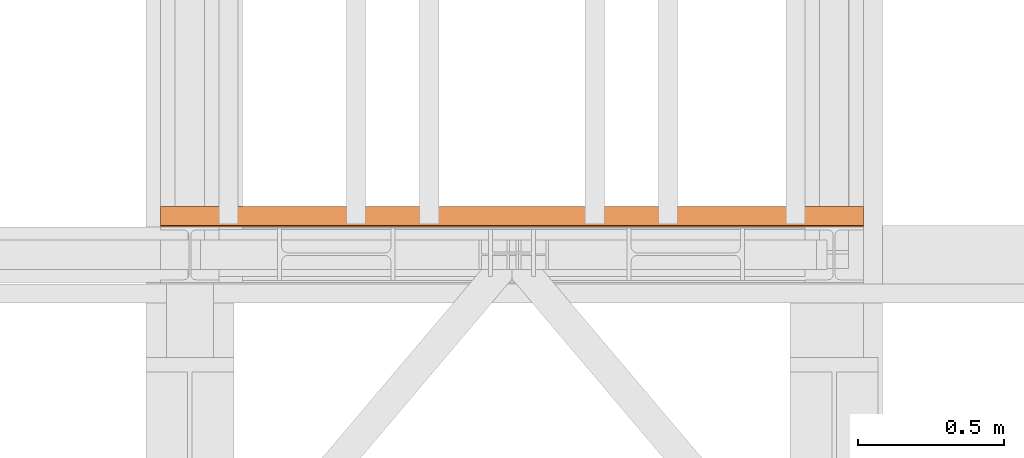
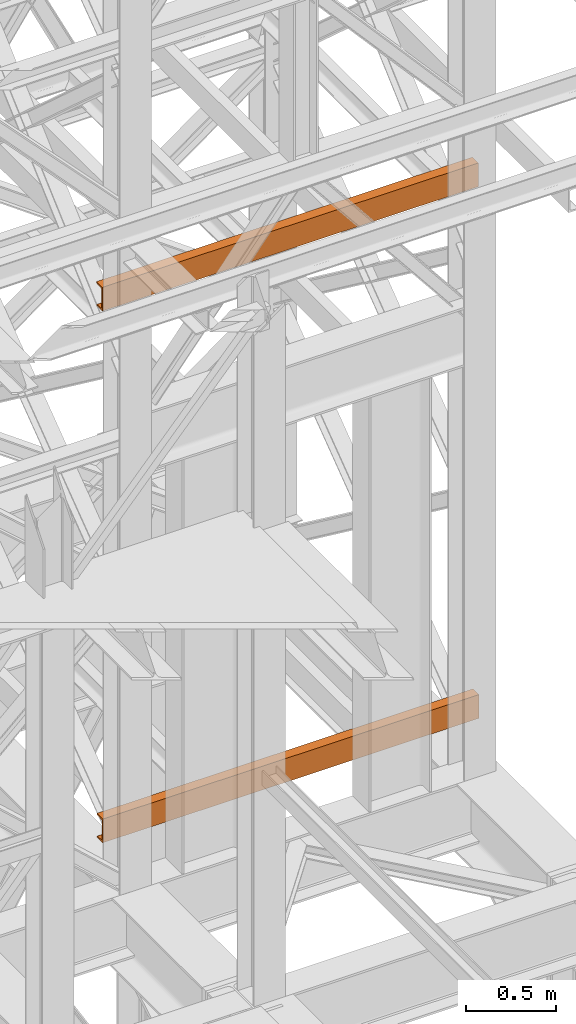
# One storey, part 179 of 208: 2 proxies.
"""IFC2X3 building model written with IfcOpenShell, lengths in millimetres."""

from ifc_helpers import new_model, entity, si_unit, converted_unit, frame, origin, origin_with_axes, place, context, subcontext, project, spatial, faceted_brep, element, save


model = new_model("IFC2X3")

# Units and contexts
model_context = context("Model", 3, precision=1e-05, world=origin())
plan_context = context("Plan", 3, precision=1e-05, world=origin())
body_context = subcontext(model_context, "Body", "Model", "MODEL_VIEW")
ifc_project = project(units=[si_unit("LENGTHUNIT", "METRE", prefix="MILLI"), converted_unit("PLANEANGLEUNIT", "DEGREE", entity("IfcPlaneAngleMeasure", 0.0174532925199433), si_unit("PLANEANGLEUNIT", "RADIAN"), dimensions=[0, 0, 0, 0, 0, 0, 0]), si_unit("AREAUNIT", "SQUARE_METRE"), si_unit("VOLUMEUNIT", "CUBIC_METRE")], contexts=[model_context, plan_context])

# Building, storey
building_placement = place(None, origin())
building = spatial("IfcBuilding", under=ifc_project, at=building_placement, CompositionType="COMPLEX")
storey_placement = place(building_placement, origin_with_axes())
storey = spatial("IfcBuildingStorey", under=building, at=storey_placement, Name="Geschoss", CompositionType="ELEMENT")

# Proxies
proxy_1_placement = place(storey_placement, frame((6493.302372304859, -15862.57438797436, 9109.989999999998), z_axis=(0.0, 0.0, 1.0), x_axis=(1.0, 0.0, 0.0)))
element("IfcBuildingElementProxy", 1, at=proxy_1_placement, inside=storey, context=body_context, shape_type="Brep", body=[
    faceted_brep([(2399.962597713924, 0.01853275732537441, 160.0100000000002), (0.009999999999308784, 0.00999999999839929, 160.0100000000002), (0.009999999999308784, 65.0099999999984, 160.0100000000002), (2399.962597713924, 65.01853275732537, 160.0100000000002), (2399.962597713924, 65.01853275732537, 160.0100000000002), (0.009999999999308784, 65.0099999999984, 160.0100000000002), (0.009999999999308784, 65.0099999999984, 156.8875719297539), (2399.962597713924, 65.01853275732537, 156.8875719297539), (2399.962597713924, 65.01853275732537, 156.8875719297539), (0.009999999999308784, 65.0099999999984, 156.8875719297539), (0.009999999999308784, 64.76726342282564, 155.2717110918293), (2399.962597713924, 64.77579618015261, 155.2717110918293), (2399.962597713924, 64.77579618015261, 155.2717110918293), (0.009999999999308784, 64.76726342282564, 155.2717110918293), (0.009999999999308784, 64.06053228585733, 153.7984655565542), (2399.962597713924, 64.06906504318067, 153.7984655565542), (2399.962597713924, 64.06906504318067, 153.7984655565542), (0.009999999999308784, 64.06053228585733, 153.7984655565542), (0.009999999999308784, 62.9521516384666, 152.5978732961266), (2399.962597713924, 62.96068439579358, 152.5978732961266), (2399.962597713924, 62.96068439579358, 152.5978732961266), (0.009999999999308784, 62.9521516384666, 152.5978732961266), (0.009999999999308784, 61.5399564114814, 151.7759086082897), (2399.962597713924, 61.54848916880837, 151.7759086082897), (2399.962597713924, 61.54848916880837, 151.7759086082897), (0.009999999999308784, 61.5399564114814, 151.7759086082897), (0.009999999999308784, 59.94859872255256, 151.4050878978051), (2399.962597713924, 59.95713147987954, 151.4050878978051), (2399.962597713924, 59.95713147987954, 151.4050878978051), (0.009999999999308784, 59.94859872255256, 151.4050878978051), (0.009999999999308784, 17.17267516602806, 147.9830140132835), (2399.962597713924, 17.18120792335503, 147.9830140132835), (2399.962597713924, 17.18120792335503, 147.9830140132835), (0.009999999999308784, 17.17267516602806, 147.9830140132835), (0.009999999999308784, 14.20840820800731, 147.318026761528), (2399.962597713924, 14.21694096533429, 147.318026761528), (2399.962597713924, 14.21694096533429, 147.318026761528), (0.009999999999308784, 14.20840820800731, 147.318026761528), (0.009999999999308784, 11.43861959928836, 145.7058782528511), (2399.962597713924, 11.4471523566117, 145.7058782528511), (2399.962597713924, 11.4471523566117, 145.7058782528511), (0.009999999999308784, 11.43861959928836, 145.7058782528511), (0.009999999999308784, 9.322620181545062, 143.4138384829421), (2399.962597713924, 9.331152938872037, 143.4138384829421), (2399.962597713924, 9.331152938872037, 143.4138384829421), (0.009999999999308784, 9.322620181545062, 143.4138384829421), (0.009999999999308784, 7.973406192784751, 140.6012788246917), (2399.962597713924, 7.981938950111726, 140.6012788246917), (2399.962597713924, 7.981938950111726, 140.6012788246917), (0.009999999999308784, 7.973406192784751, 140.6012788246917), (0.009999999999308784, 7.509999999998399, 137.5164535886543), (2399.962597713924, 7.518532757325374, 137.5164535886543), (2399.962597713924, 7.518532757325374, 137.5164535886543), (0.009999999999308784, 7.509999999998399, 137.5164535886543), (0.009999999999308784, 7.509999999998399, 22.503546411348), (2399.962597713924, 7.518532757325374, 22.503546411348), (2399.962597713924, 7.518532757325374, 22.503546411348), (0.009999999999308784, 7.509999999998399, 22.503546411348), (0.009999999999308784, 7.973406192784751, 19.41872117530875), (2399.962597713924, 7.981938950111726, 19.41872117530875), (2399.962597713924, 7.981938950111726, 19.41872117530875), (0.009999999999308784, 7.973406192784751, 19.41872117530875), (0.009999999999308784, 9.322620181545062, 16.60616151705835), (2399.962597713924, 9.331152938872037, 16.60616151705835), (2399.962597713924, 9.331152938872037, 16.60616151705835), (0.009999999999308784, 9.322620181545062, 16.60616151705835), (0.009999999999308784, 11.43861959928836, 14.31412174714933), (2399.962597713924, 11.4471523566117, 14.31412174714933), (2399.962597713924, 11.4471523566117, 14.31412174714933), (0.009999999999308784, 11.43861959928836, 14.31412174714933), (0.009999999999308784, 14.13462866898408, 12.74491643400688), (2399.962597713924, 14.14316142630742, 12.74491643400688), (2399.962597713924, 14.14316142630742, 12.74491643400688), (0.009999999999308784, 14.13462866898408, 12.74491643400688), (0.009999999999308784, 17.17267516602806, 12.03698598671872), (2399.962597713924, 17.18120792335503, 12.03698598671872), (2399.962597713924, 17.18120792335503, 12.03698598671872), (0.009999999999308784, 17.17267516602806, 12.03698598671872), (0.009999999999308784, 59.94859872255256, 8.614912102195376), (2399.962597713924, 59.95713147987954, 8.614912102195376), (2399.962597713924, 59.95713147987954, 8.614912102195376), (0.009999999999308784, 59.94859872255256, 8.614912102195376), (0.009999999999308784, 61.5399564114814, 8.244091391710754), (2399.962597713924, 61.54848916880837, 8.244091391710754), (2399.962597713924, 61.54848916880837, 8.244091391710754), (0.009999999999308784, 61.5399564114814, 8.244091391710754), (0.009999999999308784, 62.9521516384666, 7.422126703873801), (2399.962597713924, 62.96068439579358, 7.422126703873801), (2399.962597713924, 62.96068439579358, 7.422126703873801), (0.009999999999308784, 62.9521516384666, 7.422126703873801), (0.009999999999308784, 64.06053228585733, 6.221534443446217), (2399.962597713924, 64.06906504318067, 6.221534443446217), (2399.962597713924, 64.06906504318067, 6.221534443446217), (0.009999999999308784, 64.06053228585733, 6.221534443446217), (0.009999999999308784, 64.76726342282564, 4.748288908172981), (2399.962597713924, 64.77579618015261, 4.748288908172981), (2399.962597713924, 64.77579618015261, 4.748288908172981), (0.009999999999308784, 64.76726342282564, 4.748288908172981), (0.009999999999308784, 65.0099999999984, 0.01000000000021828), (2399.962597713924, 65.01853275732537, 0.01000000000021828), (2399.962597713924, 65.01853275732537, 0.01000000000021828), (0.009999999999308784, 65.0099999999984, 0.01000000000021828), (0.009999999999308784, 0.00999999999839929, 0.01000000000021828), (2399.962597713924, 0.01853275732537441, 0.01000000000021828), (2399.962597713924, 0.01853275732537441, 0.01000000000021828), (0.009999999999308784, 0.00999999999839929, 0.01000000000021828), (0.009999999999308784, 0.00999999999839929, 160.0100000000002), (2399.962597713924, 0.01853275732537441, 160.0100000000002), (2399.962597713924, 0.01853275732537441, 160.0100000000002), (2399.962597713924, 65.01853275732537, 160.0100000000002), (2399.962597713924, 65.01853275732537, 156.8875719297539), (2399.962597713924, 64.77579618015261, 155.2717110918293), (2399.962597713924, 64.06906504318067, 153.7984655565542), (2399.962597713924, 62.96068439579358, 152.5978732961266), (2399.962597713924, 61.54848916880837, 151.7759086082897), (2399.962597713924, 59.95713147987954, 151.4050878978051), (2399.962597713924, 17.18120792335503, 147.9830140132835), (2399.962597713924, 14.21694096533429, 147.318026761528), (2399.962597713924, 11.4471523566117, 145.7058782528511), (2399.962597713924, 9.331152938872037, 143.4138384829421), (2399.962597713924, 7.981938950111726, 140.6012788246917), (2399.962597713924, 7.518532757325374, 137.5164535886543), (2399.962597713924, 7.518532757325374, 22.503546411348), (2399.962597713924, 7.981938950111726, 19.41872117530875), (2399.962597713924, 9.331152938872037, 16.60616151705835), (2399.962597713924, 11.4471523566117, 14.31412174714933), (2399.962597713924, 14.14316142630742, 12.74491643400688), (2399.962597713924, 17.18120792335503, 12.03698598671872), (2399.962597713924, 59.95713147987954, 8.614912102195376), (2399.962597713924, 61.54848916880837, 8.244091391710754), (2399.962597713924, 62.96068439579358, 7.422126703873801), (2399.962597713924, 64.06906504318067, 6.221534443446217), (2399.962597713924, 64.77579618015261, 4.748288908172981), (2399.962597713924, 65.01853275732537, 0.01000000000021828), (2399.962597713924, 0.01853275732537441, 0.01000000000021828), (0.009999999999308784, 0.00999999999839929, 160.0100000000002), (0.009999999999308784, 0.00999999999839929, 0.01000000000021828), (0.009999999999308784, 65.0099999999984, 0.01000000000021828), (0.009999999999308784, 64.76726342282564, 4.748288908172981), (0.009999999999308784, 64.06053228585733, 6.221534443446217), (0.009999999999308784, 62.9521516384666, 7.422126703873801), (0.009999999999308784, 61.5399564114814, 8.244091391710754), (0.009999999999308784, 59.94859872255256, 8.614912102195376), (0.009999999999308784, 17.17267516602806, 12.03698598671872), (0.009999999999308784, 14.13462866898408, 12.74491643400688), (0.009999999999308784, 11.43861959928836, 14.31412174714933), (0.009999999999308784, 9.322620181545062, 16.60616151705835), (0.009999999999308784, 7.973406192784751, 19.41872117530875), (0.009999999999308784, 7.509999999998399, 22.503546411348), (0.009999999999308784, 7.509999999998399, 137.5164535886543), (0.009999999999308784, 7.973406192784751, 140.6012788246917), (0.009999999999308784, 9.322620181545062, 143.4138384829421), (0.009999999999308784, 11.43861959928836, 145.7058782528511), (0.009999999999308784, 14.20840820800731, 147.318026761528), (0.009999999999308784, 17.17267516602806, 147.9830140132835), (0.009999999999308784, 59.94859872255256, 151.4050878978051), (0.009999999999308784, 61.5399564114814, 151.7759086082897), (0.009999999999308784, 62.9521516384666, 152.5978732961266), (0.009999999999308784, 64.06053228585733, 153.7984655565542), (0.009999999999308784, 64.76726342282564, 155.2717110918293), (0.009999999999308784, 65.0099999999984, 156.8875719297539), (0.009999999999308784, 65.0099999999984, 160.0100000000002)], [[[0, 1, 2, 3]], [[4, 5, 6, 7]], [[8, 9, 10, 11]], [[12, 13, 14, 15]], [[16, 17, 18, 19]], [[20, 21, 22, 23]], [[24, 25, 26, 27]], [[28, 29, 30, 31]], [[32, 33, 34, 35]], [[36, 37, 38, 39]], [[40, 41, 42, 43]], [[44, 45, 46, 47]], [[48, 49, 50, 51]], [[52, 53, 54, 55]], [[56, 57, 58, 59]], [[60, 61, 62, 63]], [[64, 65, 66, 67]], [[68, 69, 70, 71]], [[72, 73, 74, 75]], [[76, 77, 78, 79]], [[80, 81, 82, 83]], [[84, 85, 86, 87]], [[88, 89, 90, 91]], [[92, 93, 94, 95]], [[96, 97, 98, 99]], [[100, 101, 102, 103]], [[104, 105, 106, 107]], [[108, 109, 110, 111, 112, 113, 114, 115, 116, 117, 118, 119, 120, 121, 122, 123, 124, 125, 126, 127, 128, 129, 130, 131, 132, 133, 134]], [[135, 136, 137, 138, 139, 140, 141, 142, 143, 144, 145, 146, 147, 148, 149, 150, 151, 152, 153, 154, 155, 156, 157, 158, 159, 160, 161]]], orient=[[False], [False], [False], [False], [False], [False], [False], [False], [False], [False], [False], [False], [False], [False], [False], [False], [False], [False], [False], [False], [False], [False], [False], [False], [False], [False], [False], [False], [False]]),
])
proxy_2_placement = place(storey_placement, frame((6493.302372304859, -15867.57438491282, 5524.960005364417), z_axis=(0.0, 0.0, 1.0), x_axis=(1.0, 0.0, 0.0)))
element("IfcBuildingElementProxy", 2, at=proxy_2_placement, inside=storey, context=body_context, shape_type="Brep", body=[
    faceted_brep([(2399.962597713924, 0.01853275732537441, 160.0100000000002), (0.009999999999308784, 0.00999999999839929, 160.0100000000002), (0.009999999999308784, 65.0099999999984, 160.0100000000002), (2399.962597713924, 65.01853275732537, 160.0100000000002), (2399.962597713924, 65.01853275732537, 160.0100000000002), (0.009999999999308784, 65.0099999999984, 160.0100000000002), (0.009999999999308784, 65.0099999999984, 156.8875719297539), (2399.962597713924, 65.01853275732537, 156.8875719297539), (2399.962597713924, 65.01853275732537, 156.8875719297539), (0.009999999999308784, 65.0099999999984, 156.8875719297539), (0.009999999999308784, 64.76726342282564, 155.2717110918293), (2399.962597713924, 64.77579618015261, 155.2717110918293), (2399.962597713924, 64.77579618015261, 155.2717110918293), (0.009999999999308784, 64.76726342282564, 155.2717110918293), (0.009999999999308784, 64.06053228585733, 153.7984655565542), (2399.962597713924, 64.06906504318067, 153.7984655565542), (2399.962597713924, 64.06906504318067, 153.7984655565542), (0.009999999999308784, 64.06053228585733, 153.7984655565542), (0.009999999999308784, 62.9521516384666, 152.5978732961266), (2399.962597713924, 62.96068439579358, 152.5978732961266), (2399.962597713924, 62.96068439579358, 152.5978732961266), (0.009999999999308784, 62.9521516384666, 152.5978732961266), (0.009999999999308784, 61.5399564114814, 151.7759086082897), (2399.962597713924, 61.54848916880837, 151.7759086082897), (2399.962597713924, 61.54848916880837, 151.7759086082897), (0.009999999999308784, 61.5399564114814, 151.7759086082897), (0.009999999999308784, 59.94859872255256, 151.4050878978051), (2399.962597713924, 59.95713147987954, 151.4050878978051), (2399.962597713924, 59.95713147987954, 151.4050878978051), (0.009999999999308784, 59.94859872255256, 151.4050878978051), (0.009999999999308784, 17.17267516602806, 147.9830140132835), (2399.962597713924, 17.18120792335503, 147.9830140132835), (2399.962597713924, 17.18120792335503, 147.9830140132835), (0.009999999999308784, 17.17267516602806, 147.9830140132835), (0.009999999999308784, 14.20840820800731, 147.318026761528), (2399.962597713924, 14.21694096533429, 147.318026761528), (2399.962597713924, 14.21694096533429, 147.318026761528), (0.009999999999308784, 14.20840820800731, 147.318026761528), (0.009999999999308784, 11.43861959928836, 145.7058782528511), (2399.962597713924, 11.4471523566117, 145.7058782528511), (2399.962597713924, 11.4471523566117, 145.7058782528511), (0.009999999999308784, 11.43861959928836, 145.7058782528511), (0.009999999999308784, 9.322620181545062, 143.4138384829421), (2399.962597713924, 9.331152938872037, 143.4138384829421), (2399.962597713924, 9.331152938872037, 143.4138384829421), (0.009999999999308784, 9.322620181545062, 143.4138384829421), (0.009999999999308784, 7.973406192784751, 140.6012788246917), (2399.962597713924, 7.981938950111726, 140.6012788246917), (2399.962597713924, 7.981938950111726, 140.6012788246917), (0.009999999999308784, 7.973406192784751, 140.6012788246917), (0.009999999999308784, 7.509999999998399, 137.5164535886543), (2399.962597713924, 7.518532757325374, 137.5164535886543), (2399.962597713924, 7.518532757325374, 137.5164535886543), (0.009999999999308784, 7.509999999998399, 137.5164535886543), (0.009999999999308784, 7.509999999998399, 22.503546411348), (2399.962597713924, 7.518532757325374, 22.503546411348), (2399.962597713924, 7.518532757325374, 22.503546411348), (0.009999999999308784, 7.509999999998399, 22.503546411348), (0.009999999999308784, 7.973406192784751, 19.41872117530875), (2399.962597713924, 7.981938950111726, 19.41872117530875), (2399.962597713924, 7.981938950111726, 19.41872117530875), (0.009999999999308784, 7.973406192784751, 19.41872117530875), (0.009999999999308784, 9.322620181545062, 16.60616151705835), (2399.962597713924, 9.331152938872037, 16.60616151705835), (2399.962597713924, 9.331152938872037, 16.60616151705835), (0.009999999999308784, 9.322620181545062, 16.60616151705835), (0.009999999999308784, 11.43861959928836, 14.31412174714933), (2399.962597713924, 11.4471523566117, 14.31412174714933), (2399.962597713924, 11.4471523566117, 14.31412174714933), (0.009999999999308784, 11.43861959928836, 14.31412174714933), (0.009999999999308784, 14.13462866898408, 12.74491643400688), (2399.962597713924, 14.14316142630742, 12.74491643400688), (2399.962597713924, 14.14316142630742, 12.74491643400688), (0.009999999999308784, 14.13462866898408, 12.74491643400688), (0.009999999999308784, 17.17267516602806, 12.03698598671872), (2399.962597713924, 17.18120792335503, 12.03698598671872), (2399.962597713924, 17.18120792335503, 12.03698598671872), (0.009999999999308784, 17.17267516602806, 12.03698598671872), (0.009999999999308784, 59.94859872255256, 8.614912102195376), (2399.962597713924, 59.95713147987954, 8.614912102195376), (2399.962597713924, 59.95713147987954, 8.614912102195376), (0.009999999999308784, 59.94859872255256, 8.614912102195376), (0.009999999999308784, 61.5399564114814, 8.244091391710754), (2399.962597713924, 61.54848916880837, 8.244091391710754), (2399.962597713924, 61.54848916880837, 8.244091391710754), (0.009999999999308784, 61.5399564114814, 8.244091391710754), (0.009999999999308784, 62.9521516384666, 7.422126703873801), (2399.962597713924, 62.96068439579358, 7.422126703873801), (2399.962597713924, 62.96068439579358, 7.422126703873801), (0.009999999999308784, 62.9521516384666, 7.422126703873801), (0.009999999999308784, 64.06053228585733, 6.221534443446217), (2399.962597713924, 64.06906504318067, 6.221534443446217), (2399.962597713924, 64.06906504318067, 6.221534443446217), (0.009999999999308784, 64.06053228585733, 6.221534443446217), (0.009999999999308784, 64.76726342282564, 4.748288908172981), (2399.962597713924, 64.77579618015261, 4.748288908172981), (2399.962597713924, 64.77579618015261, 4.748288908172981), (0.009999999999308784, 64.76726342282564, 4.748288908172981), (0.009999999999308784, 65.0099999999984, 0.01000000000021828), (2399.962597713924, 65.01853275732537, 0.01000000000021828), (2399.962597713924, 65.01853275732537, 0.01000000000021828), (0.009999999999308784, 65.0099999999984, 0.01000000000021828), (0.009999999999308784, 0.00999999999839929, 0.01000000000021828), (2399.962597713924, 0.01853275732537441, 0.01000000000021828), (2399.962597713924, 0.01853275732537441, 0.01000000000021828), (0.009999999999308784, 0.00999999999839929, 0.01000000000021828), (0.009999999999308784, 0.00999999999839929, 160.0100000000002), (2399.962597713924, 0.01853275732537441, 160.0100000000002), (2399.962597713924, 0.01853275732537441, 160.0100000000002), (2399.962597713924, 65.01853275732537, 160.0100000000002), (2399.962597713924, 65.01853275732537, 156.8875719297539), (2399.962597713924, 64.77579618015261, 155.2717110918293), (2399.962597713924, 64.06906504318067, 153.7984655565542), (2399.962597713924, 62.96068439579358, 152.5978732961266), (2399.962597713924, 61.54848916880837, 151.7759086082897), (2399.962597713924, 59.95713147987954, 151.4050878978051), (2399.962597713924, 17.18120792335503, 147.9830140132835), (2399.962597713924, 14.21694096533429, 147.318026761528), (2399.962597713924, 11.4471523566117, 145.7058782528511), (2399.962597713924, 9.331152938872037, 143.4138384829421), (2399.962597713924, 7.981938950111726, 140.6012788246917), (2399.962597713924, 7.518532757325374, 137.5164535886543), (2399.962597713924, 7.518532757325374, 22.503546411348), (2399.962597713924, 7.981938950111726, 19.41872117530875), (2399.962597713924, 9.331152938872037, 16.60616151705835), (2399.962597713924, 11.4471523566117, 14.31412174714933), (2399.962597713924, 14.14316142630742, 12.74491643400688), (2399.962597713924, 17.18120792335503, 12.03698598671872), (2399.962597713924, 59.95713147987954, 8.614912102195376), (2399.962597713924, 61.54848916880837, 8.244091391710754), (2399.962597713924, 62.96068439579358, 7.422126703873801), (2399.962597713924, 64.06906504318067, 6.221534443446217), (2399.962597713924, 64.77579618015261, 4.748288908172981), (2399.962597713924, 65.01853275732537, 0.01000000000021828), (2399.962597713924, 0.01853275732537441, 0.01000000000021828), (0.009999999999308784, 0.00999999999839929, 160.0100000000002), (0.009999999999308784, 0.00999999999839929, 0.01000000000021828), (0.009999999999308784, 65.0099999999984, 0.01000000000021828), (0.009999999999308784, 64.76726342282564, 4.748288908172981), (0.009999999999308784, 64.06053228585733, 6.221534443446217), (0.009999999999308784, 62.9521516384666, 7.422126703873801), (0.009999999999308784, 61.5399564114814, 8.244091391710754), (0.009999999999308784, 59.94859872255256, 8.614912102195376), (0.009999999999308784, 17.17267516602806, 12.03698598671872), (0.009999999999308784, 14.13462866898408, 12.74491643400688), (0.009999999999308784, 11.43861959928836, 14.31412174714933), (0.009999999999308784, 9.322620181545062, 16.60616151705835), (0.009999999999308784, 7.973406192784751, 19.41872117530875), (0.009999999999308784, 7.509999999998399, 22.503546411348), (0.009999999999308784, 7.509999999998399, 137.5164535886543), (0.009999999999308784, 7.973406192784751, 140.6012788246917), (0.009999999999308784, 9.322620181545062, 143.4138384829421), (0.009999999999308784, 11.43861959928836, 145.7058782528511), (0.009999999999308784, 14.20840820800731, 147.318026761528), (0.009999999999308784, 17.17267516602806, 147.9830140132835), (0.009999999999308784, 59.94859872255256, 151.4050878978051), (0.009999999999308784, 61.5399564114814, 151.7759086082897), (0.009999999999308784, 62.9521516384666, 152.5978732961266), (0.009999999999308784, 64.06053228585733, 153.7984655565542), (0.009999999999308784, 64.76726342282564, 155.2717110918293), (0.009999999999308784, 65.0099999999984, 156.8875719297539), (0.009999999999308784, 65.0099999999984, 160.0100000000002)], [[[0, 1, 2, 3]], [[4, 5, 6, 7]], [[8, 9, 10, 11]], [[12, 13, 14, 15]], [[16, 17, 18, 19]], [[20, 21, 22, 23]], [[24, 25, 26, 27]], [[28, 29, 30, 31]], [[32, 33, 34, 35]], [[36, 37, 38, 39]], [[40, 41, 42, 43]], [[44, 45, 46, 47]], [[48, 49, 50, 51]], [[52, 53, 54, 55]], [[56, 57, 58, 59]], [[60, 61, 62, 63]], [[64, 65, 66, 67]], [[68, 69, 70, 71]], [[72, 73, 74, 75]], [[76, 77, 78, 79]], [[80, 81, 82, 83]], [[84, 85, 86, 87]], [[88, 89, 90, 91]], [[92, 93, 94, 95]], [[96, 97, 98, 99]], [[100, 101, 102, 103]], [[104, 105, 106, 107]], [[108, 109, 110, 111, 112, 113, 114, 115, 116, 117, 118, 119, 120, 121, 122, 123, 124, 125, 126, 127, 128, 129, 130, 131, 132, 133, 134]], [[135, 136, 137, 138, 139, 140, 141, 142, 143, 144, 145, 146, 147, 148, 149, 150, 151, 152, 153, 154, 155, 156, 157, 158, 159, 160, 161]]], orient=[[False], [False], [False], [False], [False], [False], [False], [False], [False], [False], [False], [False], [False], [False], [False], [False], [False], [False], [False], [False], [False], [False], [False], [False], [False], [False], [False], [False], [False]]),
])

save(model, "model.ifc")
